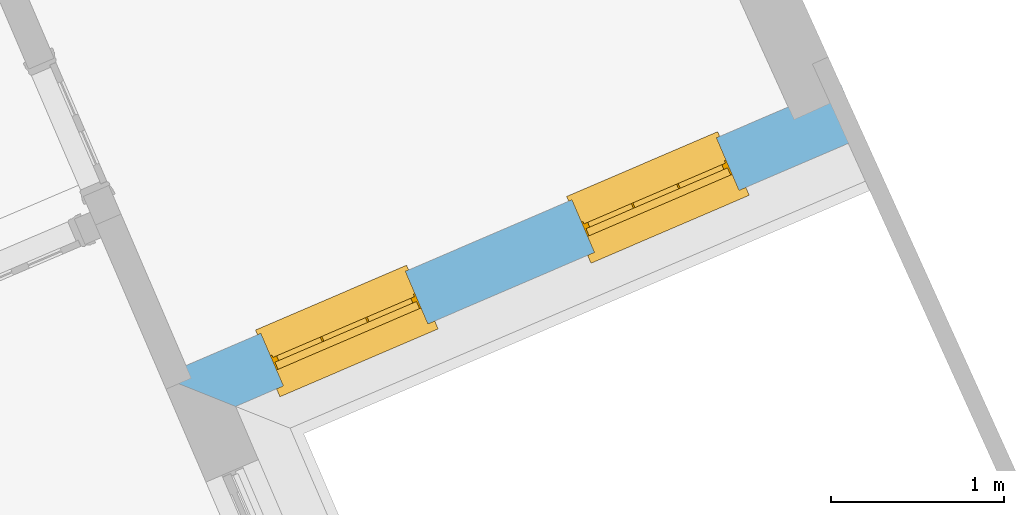
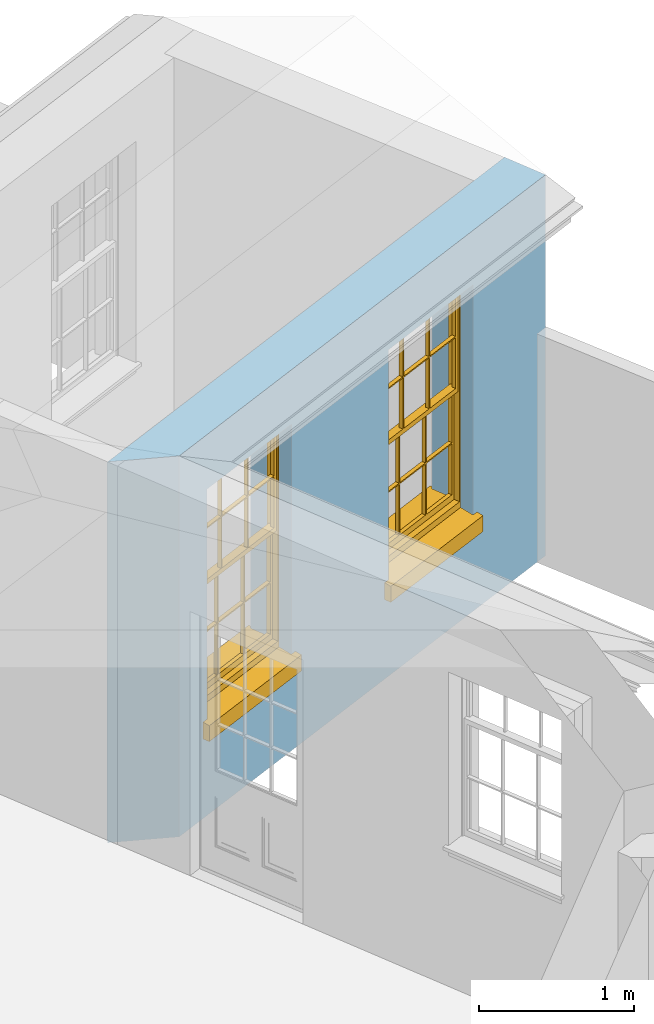
# One storey, part 14 of 19: 2 windows, 2 openings, plus 1 element that does not belong to this part.
"""IFC2X3 building model written with IfcOpenShell, lengths in metres."""

from ifc_helpers import new_model, si_unit, frame, origin, place, context, subcontext, project, spatial, polyline, outline, extrude, faceted_brep, material, layer, layer_set, layer_usage, element, fill, save


model = new_model("IFC2X3")

# Units and contexts
model_context = context("Model", 3, world=origin())
body_context = subcontext(model_context, "Body", "Model", "MODEL_VIEW")
ifc_project = project(units=[si_unit("PLANEANGLEUNIT", "RADIAN"), si_unit("MASSUNIT", "GRAM", prefix="KILO"), si_unit("FORCEUNIT", "NEWTON", prefix="KILO"), si_unit("LENGTHUNIT", "METRE")], contexts=[model_context])

# Site, building, storey
site_placement = place(None, origin())
site = spatial("IfcSite", under=ifc_project, at=site_placement, CompositionType="ELEMENT")
building_placement = place(None, origin())
building = spatial("IfcBuilding", under=site, at=building_placement, Name="Building plot-0", CompositionType="ELEMENT")
storey_placement = place(None, origin())
storey = spatial("IfcBuildingStorey", under=building, at=storey_placement, Name="Floor 0", CompositionType="ELEMENT", Elevation=0.0)

# Wall, openings, windows
ifc_material = material(Name="Masonry")
ifc_layer = layer(ifc_material, 0.33, ventilated=False)
ifc_layer_set = layer_set([ifc_layer], Name="My Wall")
ifc_layer_usage = layer_usage(ifc_layer_set, "AXIS2", "NEGATIVE", 0.08)
wall_placement = place(storey_placement, origin())
wall = element("IfcWallStandardCase", 1, at=wall_placement, inside=storey, material=ifc_layer_usage, Name="exterior", context=body_context, shape_type="SweptSolid", body=[
    extrude(outline(polyline([(22.5638042639667, 27.6756383909319), (22.9972229109118, 27.5025826875291), (26.6256869190706, 29.0603032558596), (26.4955054472994, 29.3635404310336), (22.5638042639667, 27.6756383909319)])), origin(), (0.0, 0.0, 1.0), 3.0),
])
opening_1_placement = place(storey_placement, frame((0.0, 0.0, 0.75)))
opening_1 = element("IfcOpeningElement", 2, at=opening_1_placement, cuts=wall, Name="Opening", ObjectType="Opening", context=body_context, shape_type="SweptSolid", body=[
    extrude(outline(polyline([(23.2728930701609, 27.6209294800484), (24.1090925532164, 27.9799147506902), (23.9789110814452, 28.2831519258642), (23.1427115983897, 27.9241666552224), (23.2728930701609, 27.6209294800484)])), origin(), (0.0, 0.0, 1.0), 1.82),
])
opening_2_placement = place(storey_placement, frame((0.0, 0.0, 0.75)))
opening_2 = element("IfcOpeningElement", 3, at=opening_2_placement, cuts=wall, Name="Opening", ObjectType="Opening", context=body_context, shape_type="SweptSolid", body=[
    extrude(outline(polyline([(25.0707460427957, 28.3927581513567), (25.9069455258511, 28.7517434219985), (25.7767640540799, 29.0549805971725), (24.9405645710245, 28.6959953265307), (25.0707460427957, 28.3927581513567)])), origin(), (0.0, 0.0, 1.0), 1.82),
])
window_1_placement = place(storey_placement, frame((23.1742707430615, 27.850654612756, 0.75), z_axis=(0.0, 0.0, 1.0), x_axis=(0.836199483055477, 0.358985270641782, 0.0)))
window_1 = element("IfcWindow", 4, at=window_1_placement, inside=storey, Name="toilet outside window", OverallHeight=1.82, OverallWidth=0.91, context=body_context, shape_type="Brep", held_by="IfcProductRepresentation", body=[
    faceted_brep([(0.033125, -0.105, 0.975209), (0.01, -0.105, 0.975209), (0.033125, -0.105, 1.376042), (0.876875, -0.105, 0.975209), (0.876875, -0.105, 1.376042), (0.9, -0.105, 0.975209), (0.876875, -0.105, 1.386042), (0.876875, -0.105, 1.786875), (0.9, -0.105, 1.81), (0.033125, -0.105, 1.786875), (0.033125, -0.105, 1.386042), (0.01, -0.105, 1.81), (0.876875, -0.135, 1.376042), (0.876875, -0.135, 0.975209), (0.9, -0.135, 0.937083), (0.033125, -0.135, 1.786875), (0.01, -0.135, 1.81), (0.033125, -0.135, 1.386042), (0.01, -0.135, 0.937083), (0.033125, -0.135, 0.975209), (0.033125, -0.135, 1.376042), (0.876875, -0.135, 1.786875), (0.876875, -0.135, 1.386042), (0.9, -0.135, 1.81), (0.033125, -0.105, 0.937083), (0.01, -0.105, 0.937083), (0.033125, -0.105, 0.53625), (0.876875, -0.105, 0.937083), (0.876875, -0.105, 0.53625), (0.9, -0.105, 0.937083), (0.876875, -0.105, 0.52625), (0.876875, -0.105, 0.125417), (0.9, -0.105, 0.077167), (0.033125, -0.105, 0.125417), (0.033125, -0.105, 0.52625), (0.01, -0.105, 0.077167), (-0.0425, -0.25, 0.01), (-0.0425, -0.3, 0.001667), (0.0, -0.25, 0.01), (0.9525, -0.25, 0.01), (0.91, -0.25, 0.01), (0.9525, -0.3, 0.001667), (-0.02, 0.08, 0.077167), (0.0, 0.08, 0.077167), (-0.02, 0.11, 0.077167), (0.0, -0.06, 0.077167), (0.01, -0.06, 0.077167), (0.91, -0.06, 0.077167), (0.91, 0.08, 0.077167), (0.9, -0.06, 0.077167), (0.93, 0.08, 0.077167), (0.93, 0.11, 0.077167), (0.01, -0.075, 0.975209), (0.9, -0.075, 0.975209), (0.876875, -0.075, 0.125417), (0.876875, -0.075, 0.52625), (0.9, -0.075, 0.077167), (0.876875, -0.075, 0.53625), (0.876875, -0.075, 0.937083), (0.033125, -0.075, 0.125417), (0.01, -0.075, 0.077167), (0.033125, -0.075, 0.52625), (0.033125, -0.075, 0.937083), (0.033125, -0.075, 0.53625), (-0.02, 0.08, 0.052167), (-0.02, 0.11, 0.052167), (0.93, 0.11, 0.052167), (0.93, 0.08, 0.052167), (0.91, 0.08, 0.052167), (0.0, 0.08, 0.052167), (0.91, -0.15, 0.026667), (0.0, -0.15, 0.026667), (-0.0425, -0.3, -0.123333), (0.9525, -0.3, -0.123333), (-0.0425, -0.25, -0.123333), (0.9525, -0.25, -0.123333), (0.01, -0.06, 1.81), (0.9, -0.06, 1.81), (0.0, -0.06, 1.82), (0.91, -0.06, 1.82), (0.01, -0.15, 0.077167), (0.9, -0.15, 0.077167), (0.592292, -0.105, 0.125417), (0.592292, -0.075, 0.125417), (0.317708, -0.075, 0.125417), (0.317708, -0.105, 0.125417), (0.592292, -0.105, 0.53625), (0.317708, -0.105, 0.53625), (0.317708, -0.105, 0.52625), (0.592292, -0.105, 0.52625), (0.592292, -0.075, 0.53625), (0.317708, -0.075, 0.53625), (0.592292, -0.135, 1.386042), (0.592292, -0.105, 1.386042), (0.317708, -0.105, 1.386042), (0.317708, -0.135, 1.386042), (0.317708, -0.135, 1.376042), (0.592292, -0.135, 1.376042), (0.317708, -0.105, 1.376042), (0.592292, -0.105, 1.376042), (0.602292, -0.135, 1.376042), (0.592292, -0.135, 0.975209), (0.602292, -0.135, 0.975209), (0.602292, -0.105, 0.975209), (0.592292, -0.105, 0.975209), (0.602292, -0.105, 1.376042), (0.602292, -0.075, 0.53625), (0.602292, -0.105, 0.53625), (0.317708, -0.075, 0.52625), (0.307708, -0.075, 0.125417), (0.307708, -0.075, 0.52625), (0.602292, -0.075, 0.52625), (0.602292, -0.075, 0.125417), (0.592292, -0.075, 0.52625), (0.307708, -0.075, 0.53625), (0.317708, -0.075, 0.937083), (0.307708, -0.075, 0.937083), (0.602292, -0.075, 0.937083), (0.592292, -0.075, 0.937083), (0.307708, -0.105, 0.52625), (0.307708, -0.105, 0.125417), (0.307708, -0.105, 0.53625), (0.307708, -0.105, 0.937083), (0.592292, -0.105, 0.937083), (0.317708, -0.105, 0.937083), (0.602292, -0.105, 0.937083), (0.602292, -0.105, 0.52625), (0.602292, -0.105, 0.125417), (0.307708, -0.135, 1.386042), (0.307708, -0.135, 1.376042), (0.307708, -0.135, 0.975209), (0.317708, -0.135, 0.975209), (0.317708, -0.135, 1.786875), (0.307708, -0.135, 1.786875), (0.602292, -0.135, 1.786875), (0.592292, -0.135, 1.786875), (0.602292, -0.135, 1.386042), (0.602292, -0.105, 1.386042), (0.307708, -0.105, 1.386042), (0.307708, -0.105, 1.786875), (0.317708, -0.105, 1.786875), (0.592292, -0.105, 1.786875), (0.602292, -0.105, 1.786875), (0.307708, -0.105, 1.376042), (0.317708, -0.105, 0.975209), (0.307708, -0.105, 0.975209), (0.91, -0.15, 1.82), (0.9, -0.15, 1.81), (0.01, -0.15, 1.81), (0.0, -0.15, 1.82), (0.91, -0.25, 0.0), (0.0, -0.25, 0.0), (0.91, 0.08, 0.0), (0.0, 0.08, 0.0)], [[[0, 1, 2]], [[3, 4, 5]], [[6, 7, 8]], [[9, 10, 11]], [[12, 13, 14]], [[15, 16, 17]], [[18, 19, 20]], [[21, 22, 23]], [[24, 25, 26]], [[27, 28, 29]], [[30, 31, 32]], [[33, 34, 35]], [[14, 27, 29]], [[25, 24, 18]], [[36, 37, 38]], [[39, 40, 41]], [[42, 43, 44]], [[45, 46, 43]], [[47, 48, 49]], [[50, 51, 48]], [[1, 0, 52]], [[5, 53, 3]], [[54, 55, 56]], [[57, 58, 53]], [[59, 60, 61]], [[62, 63, 52]], [[48, 43, 46, 49]], [[51, 44, 43, 48]], [[64, 42, 44, 65]], [[65, 44, 51, 66]], [[66, 51, 50, 67]], [[65, 66, 68, 69]], [[60, 56, 49, 46]], [[70, 71, 38, 40]], [[37, 41, 40, 38]], [[37, 72, 73, 41]], [[74, 75, 73, 72]], [[8, 11, 76, 77]], [[76, 78, 79, 77]], [[32, 35, 80, 81]], [[81, 80, 71, 70]], [[82, 83, 84, 85]], [[86, 87, 88, 89]], [[86, 90, 91, 87]], [[92, 93, 94, 95]], [[92, 95, 96, 97]], [[96, 98, 99, 97]], [[100, 97, 101, 102]], [[103, 104, 99, 105]], [[97, 99, 104, 101]], [[102, 103, 105, 100]], [[28, 57, 106, 107]], [[108, 84, 109, 110]], [[111, 112, 83, 113]], [[114, 110, 61, 63]], [[90, 113, 108, 91]], [[115, 91, 114, 116]], [[117, 106, 90, 118]], [[111, 106, 57, 55]], [[119, 110, 109, 120]], [[34, 61, 110, 119]], [[89, 113, 83, 82]], [[88, 108, 113, 89]], [[85, 84, 108, 88]], [[121, 114, 63, 26]], [[122, 116, 114, 121]], [[123, 118, 90, 86]], [[87, 91, 115, 124]], [[107, 106, 117, 125]], [[126, 111, 55, 30]], [[127, 112, 111, 126]], [[126, 30, 28, 107]], [[88, 119, 120, 85]], [[126, 89, 82, 127]], [[125, 123, 86, 107]], [[121, 26, 34, 119]], [[124, 122, 121, 87]], [[128, 17, 20, 129]], [[96, 129, 130, 131]], [[132, 133, 128, 95]], [[134, 135, 92, 136]], [[100, 12, 22, 136]], [[137, 6, 4, 105]], [[94, 138, 139, 140]], [[137, 93, 141, 142]], [[99, 98, 94, 93]], [[143, 2, 10, 138]], [[144, 145, 143, 98]], [[129, 143, 145, 130]], [[20, 2, 143, 129]], [[131, 144, 98, 96]], [[128, 138, 10, 17]], [[133, 139, 138, 128]], [[135, 141, 93, 92]], [[95, 94, 140, 132]], [[22, 6, 137, 136]], [[136, 137, 142, 134]], [[100, 105, 4, 12]], [[107, 86, 89, 126]], [[106, 111, 113, 90]], [[91, 108, 110, 114]], [[87, 121, 119, 88]], [[97, 100, 136, 92]], [[129, 96, 95, 128]], [[98, 143, 138, 94]], [[105, 99, 93, 137]], [[131, 101, 104, 144]], [[124, 115, 118, 123]], [[132, 140, 141, 135]], [[120, 109, 59, 33]], [[15, 9, 139, 133]], [[134, 142, 7, 21]], [[31, 54, 112, 127]], [[36, 74, 72, 37]], [[39, 41, 73, 75]], [[18, 14, 101, 131]], [[23, 16, 132, 135]], [[83, 56, 60, 84]], [[52, 53, 118, 115]], [[53, 52, 144, 104]], [[11, 8, 141, 140]], [[14, 18, 124, 123]], [[2, 1, 11, 10]], [[8, 5, 4, 6]], [[57, 53, 56, 55]], [[60, 52, 63, 61]], [[26, 25, 35, 34]], [[32, 29, 28, 30]], [[14, 23, 22, 12]], [[18, 20, 17, 16]], [[19, 0, 2, 20]], [[17, 10, 9, 15]], [[12, 4, 3, 13]], [[21, 7, 6, 22]], [[27, 58, 57, 28]], [[30, 55, 54, 31]], [[33, 59, 61, 34]], [[26, 63, 62, 24]], [[5, 8, 77, 53]], [[76, 11, 1, 52]], [[46, 45, 78, 76]], [[49, 77, 79, 47]], [[70, 146, 147, 81]], [[71, 80, 148, 149]], [[19, 130, 145, 0]], [[102, 13, 3, 103]], [[116, 122, 24, 62]], [[29, 32, 81, 14]], [[80, 35, 25, 18]], [[60, 46, 76, 52]], [[77, 49, 56, 53]], [[23, 14, 81, 147]], [[16, 148, 80, 18]], [[35, 85, 120]], [[120, 33, 35]], [[127, 82, 32]], [[32, 31, 127]], [[32, 82, 85, 35]], [[102, 101, 14]], [[14, 13, 102]], [[18, 131, 130]], [[130, 19, 18]], [[134, 21, 23]], [[23, 135, 134]], [[16, 15, 133]], [[133, 132, 16]], [[11, 140, 139]], [[139, 9, 11]], [[142, 141, 8]], [[8, 7, 142]], [[23, 147, 148, 16]], [[146, 149, 148, 147]], [[52, 115, 116]], [[116, 62, 52]], [[118, 53, 117]], [[58, 117, 53]], [[27, 125, 117, 58]], [[56, 83, 112]], [[112, 54, 56]], [[109, 84, 60]], [[60, 59, 109]], [[125, 27, 14]], [[14, 123, 125]], [[122, 124, 18]], [[18, 24, 122]], [[145, 144, 52]], [[52, 0, 145]], [[103, 3, 53]], [[53, 104, 103]], [[79, 78, 149, 146]], [[78, 45, 71, 149]], [[146, 70, 47, 79]], [[150, 75, 74, 151]], [[68, 66, 67]], [[48, 68, 67, 50]], [[69, 64, 65]], [[42, 64, 69, 43]], [[69, 68, 152, 153]], [[70, 68, 48, 47]], [[150, 152, 68, 70]], [[43, 69, 71, 45]], [[69, 153, 151, 71]], [[152, 150, 151, 153]], [[38, 151, 74, 36]], [[71, 151, 38]], [[39, 75, 150, 40]], [[40, 150, 70]]]),
])
fill(opening_1, window_1)
window_2_placement = place(storey_placement, frame((24.9721237156963, 28.6224832840643, 0.75), z_axis=(0.0, 0.0, 1.0), x_axis=(0.836199483055477, 0.358985270641782, 0.0)))
window_2 = element("IfcWindow", 5, at=window_2_placement, inside=storey, Name="toilet outside window", OverallHeight=1.82, OverallWidth=0.91, context=body_context, shape_type="Brep", held_by="IfcProductRepresentation", body=[
    faceted_brep([(0.033125, -0.105, 0.975209), (0.01, -0.105, 0.975209), (0.033125, -0.105, 1.376042), (0.876875, -0.105, 0.975209), (0.876875, -0.105, 1.376042), (0.9, -0.105, 0.975209), (0.876875, -0.105, 1.386042), (0.876875, -0.105, 1.786875), (0.9, -0.105, 1.81), (0.033125, -0.105, 1.786875), (0.033125, -0.105, 1.386042), (0.01, -0.105, 1.81), (0.876875, -0.135, 1.376042), (0.876875, -0.135, 0.975209), (0.9, -0.135, 0.937083), (0.033125, -0.135, 1.786875), (0.01, -0.135, 1.81), (0.033125, -0.135, 1.386042), (0.01, -0.135, 0.937083), (0.033125, -0.135, 0.975209), (0.033125, -0.135, 1.376042), (0.876875, -0.135, 1.786875), (0.876875, -0.135, 1.386042), (0.9, -0.135, 1.81), (0.033125, -0.105, 0.937083), (0.01, -0.105, 0.937083), (0.033125, -0.105, 0.53625), (0.876875, -0.105, 0.937083), (0.876875, -0.105, 0.53625), (0.9, -0.105, 0.937083), (0.876875, -0.105, 0.52625), (0.876875, -0.105, 0.125417), (0.9, -0.105, 0.077167), (0.033125, -0.105, 0.125417), (0.033125, -0.105, 0.52625), (0.01, -0.105, 0.077167), (-0.0425, -0.25, 0.01), (-0.0425, -0.3, 0.001667), (0.0, -0.25, 0.01), (0.9525, -0.25, 0.01), (0.91, -0.25, 0.01), (0.9525, -0.3, 0.001667), (-0.02, 0.08, 0.077167), (0.0, 0.08, 0.077167), (-0.02, 0.11, 0.077167), (0.0, -0.06, 0.077167), (0.01, -0.06, 0.077167), (0.91, -0.06, 0.077167), (0.91, 0.08, 0.077167), (0.9, -0.06, 0.077167), (0.93, 0.08, 0.077167), (0.93, 0.11, 0.077167), (0.01, -0.075, 0.975209), (0.9, -0.075, 0.975209), (0.876875, -0.075, 0.125417), (0.876875, -0.075, 0.52625), (0.9, -0.075, 0.077167), (0.876875, -0.075, 0.53625), (0.876875, -0.075, 0.937083), (0.033125, -0.075, 0.125417), (0.01, -0.075, 0.077167), (0.033125, -0.075, 0.52625), (0.033125, -0.075, 0.937083), (0.033125, -0.075, 0.53625), (-0.02, 0.08, 0.052167), (-0.02, 0.11, 0.052167), (0.93, 0.11, 0.052167), (0.93, 0.08, 0.052167), (0.91, 0.08, 0.052167), (0.0, 0.08, 0.052167), (0.91, -0.15, 0.026667), (0.0, -0.15, 0.026667), (-0.0425, -0.3, -0.123333), (0.9525, -0.3, -0.123333), (-0.0425, -0.25, -0.123333), (0.9525, -0.25, -0.123333), (0.01, -0.06, 1.81), (0.9, -0.06, 1.81), (0.0, -0.06, 1.82), (0.91, -0.06, 1.82), (0.01, -0.15, 0.077167), (0.9, -0.15, 0.077167), (0.592292, -0.105, 0.125417), (0.592292, -0.075, 0.125417), (0.317708, -0.075, 0.125417), (0.317708, -0.105, 0.125417), (0.592292, -0.105, 0.53625), (0.317708, -0.105, 0.53625), (0.317708, -0.105, 0.52625), (0.592292, -0.105, 0.52625), (0.592292, -0.075, 0.53625), (0.317708, -0.075, 0.53625), (0.592292, -0.135, 1.386042), (0.592292, -0.105, 1.386042), (0.317708, -0.105, 1.386042), (0.317708, -0.135, 1.386042), (0.317708, -0.135, 1.376042), (0.592292, -0.135, 1.376042), (0.317708, -0.105, 1.376042), (0.592292, -0.105, 1.376042), (0.602292, -0.135, 1.376042), (0.592292, -0.135, 0.975209), (0.602292, -0.135, 0.975209), (0.602292, -0.105, 0.975209), (0.592292, -0.105, 0.975209), (0.602292, -0.105, 1.376042), (0.602292, -0.075, 0.53625), (0.602292, -0.105, 0.53625), (0.317708, -0.075, 0.52625), (0.307708, -0.075, 0.125417), (0.307708, -0.075, 0.52625), (0.602292, -0.075, 0.52625), (0.602292, -0.075, 0.125417), (0.592292, -0.075, 0.52625), (0.307708, -0.075, 0.53625), (0.317708, -0.075, 0.937083), (0.307708, -0.075, 0.937083), (0.602292, -0.075, 0.937083), (0.592292, -0.075, 0.937083), (0.307708, -0.105, 0.52625), (0.307708, -0.105, 0.125417), (0.307708, -0.105, 0.53625), (0.307708, -0.105, 0.937083), (0.592292, -0.105, 0.937083), (0.317708, -0.105, 0.937083), (0.602292, -0.105, 0.937083), (0.602292, -0.105, 0.52625), (0.602292, -0.105, 0.125417), (0.307708, -0.135, 1.386042), (0.307708, -0.135, 1.376042), (0.307708, -0.135, 0.975209), (0.317708, -0.135, 0.975209), (0.317708, -0.135, 1.786875), (0.307708, -0.135, 1.786875), (0.602292, -0.135, 1.786875), (0.592292, -0.135, 1.786875), (0.602292, -0.135, 1.386042), (0.602292, -0.105, 1.386042), (0.307708, -0.105, 1.386042), (0.307708, -0.105, 1.786875), (0.317708, -0.105, 1.786875), (0.592292, -0.105, 1.786875), (0.602292, -0.105, 1.786875), (0.307708, -0.105, 1.376042), (0.317708, -0.105, 0.975209), (0.307708, -0.105, 0.975209), (0.91, -0.15, 1.82), (0.9, -0.15, 1.81), (0.01, -0.15, 1.81), (0.0, -0.15, 1.82), (0.91, -0.25, 0.0), (0.0, -0.25, 0.0), (0.91, 0.08, 0.0), (0.0, 0.08, 0.0)], [[[0, 1, 2]], [[3, 4, 5]], [[6, 7, 8]], [[9, 10, 11]], [[12, 13, 14]], [[15, 16, 17]], [[18, 19, 20]], [[21, 22, 23]], [[24, 25, 26]], [[27, 28, 29]], [[30, 31, 32]], [[33, 34, 35]], [[14, 27, 29]], [[25, 24, 18]], [[36, 37, 38]], [[39, 40, 41]], [[42, 43, 44]], [[45, 46, 43]], [[47, 48, 49]], [[50, 51, 48]], [[1, 0, 52]], [[5, 53, 3]], [[54, 55, 56]], [[57, 58, 53]], [[59, 60, 61]], [[62, 63, 52]], [[48, 43, 46, 49]], [[51, 44, 43, 48]], [[64, 42, 44, 65]], [[65, 44, 51, 66]], [[66, 51, 50, 67]], [[65, 66, 68, 69]], [[60, 56, 49, 46]], [[70, 71, 38, 40]], [[37, 41, 40, 38]], [[37, 72, 73, 41]], [[74, 75, 73, 72]], [[8, 11, 76, 77]], [[76, 78, 79, 77]], [[32, 35, 80, 81]], [[81, 80, 71, 70]], [[82, 83, 84, 85]], [[86, 87, 88, 89]], [[86, 90, 91, 87]], [[92, 93, 94, 95]], [[92, 95, 96, 97]], [[96, 98, 99, 97]], [[100, 97, 101, 102]], [[103, 104, 99, 105]], [[97, 99, 104, 101]], [[102, 103, 105, 100]], [[28, 57, 106, 107]], [[108, 84, 109, 110]], [[111, 112, 83, 113]], [[114, 110, 61, 63]], [[90, 113, 108, 91]], [[115, 91, 114, 116]], [[117, 106, 90, 118]], [[111, 106, 57, 55]], [[119, 110, 109, 120]], [[34, 61, 110, 119]], [[89, 113, 83, 82]], [[88, 108, 113, 89]], [[85, 84, 108, 88]], [[121, 114, 63, 26]], [[122, 116, 114, 121]], [[123, 118, 90, 86]], [[87, 91, 115, 124]], [[107, 106, 117, 125]], [[126, 111, 55, 30]], [[127, 112, 111, 126]], [[126, 30, 28, 107]], [[88, 119, 120, 85]], [[126, 89, 82, 127]], [[125, 123, 86, 107]], [[121, 26, 34, 119]], [[124, 122, 121, 87]], [[128, 17, 20, 129]], [[96, 129, 130, 131]], [[132, 133, 128, 95]], [[134, 135, 92, 136]], [[100, 12, 22, 136]], [[137, 6, 4, 105]], [[94, 138, 139, 140]], [[137, 93, 141, 142]], [[99, 98, 94, 93]], [[143, 2, 10, 138]], [[144, 145, 143, 98]], [[129, 143, 145, 130]], [[20, 2, 143, 129]], [[131, 144, 98, 96]], [[128, 138, 10, 17]], [[133, 139, 138, 128]], [[135, 141, 93, 92]], [[95, 94, 140, 132]], [[22, 6, 137, 136]], [[136, 137, 142, 134]], [[100, 105, 4, 12]], [[107, 86, 89, 126]], [[106, 111, 113, 90]], [[91, 108, 110, 114]], [[87, 121, 119, 88]], [[97, 100, 136, 92]], [[129, 96, 95, 128]], [[98, 143, 138, 94]], [[105, 99, 93, 137]], [[131, 101, 104, 144]], [[124, 115, 118, 123]], [[132, 140, 141, 135]], [[120, 109, 59, 33]], [[15, 9, 139, 133]], [[134, 142, 7, 21]], [[31, 54, 112, 127]], [[36, 74, 72, 37]], [[39, 41, 73, 75]], [[18, 14, 101, 131]], [[23, 16, 132, 135]], [[83, 56, 60, 84]], [[52, 53, 118, 115]], [[53, 52, 144, 104]], [[11, 8, 141, 140]], [[14, 18, 124, 123]], [[2, 1, 11, 10]], [[8, 5, 4, 6]], [[57, 53, 56, 55]], [[60, 52, 63, 61]], [[26, 25, 35, 34]], [[32, 29, 28, 30]], [[14, 23, 22, 12]], [[18, 20, 17, 16]], [[19, 0, 2, 20]], [[17, 10, 9, 15]], [[12, 4, 3, 13]], [[21, 7, 6, 22]], [[27, 58, 57, 28]], [[30, 55, 54, 31]], [[33, 59, 61, 34]], [[26, 63, 62, 24]], [[5, 8, 77, 53]], [[76, 11, 1, 52]], [[46, 45, 78, 76]], [[49, 77, 79, 47]], [[70, 146, 147, 81]], [[71, 80, 148, 149]], [[19, 130, 145, 0]], [[102, 13, 3, 103]], [[116, 122, 24, 62]], [[29, 32, 81, 14]], [[80, 35, 25, 18]], [[60, 46, 76, 52]], [[77, 49, 56, 53]], [[23, 14, 81, 147]], [[16, 148, 80, 18]], [[35, 85, 120]], [[120, 33, 35]], [[127, 82, 32]], [[32, 31, 127]], [[32, 82, 85, 35]], [[102, 101, 14]], [[14, 13, 102]], [[18, 131, 130]], [[130, 19, 18]], [[134, 21, 23]], [[23, 135, 134]], [[16, 15, 133]], [[133, 132, 16]], [[11, 140, 139]], [[139, 9, 11]], [[142, 141, 8]], [[8, 7, 142]], [[23, 147, 148, 16]], [[146, 149, 148, 147]], [[52, 115, 116]], [[116, 62, 52]], [[118, 53, 117]], [[58, 117, 53]], [[27, 125, 117, 58]], [[56, 83, 112]], [[112, 54, 56]], [[109, 84, 60]], [[60, 59, 109]], [[125, 27, 14]], [[14, 123, 125]], [[122, 124, 18]], [[18, 24, 122]], [[145, 144, 52]], [[52, 0, 145]], [[103, 3, 53]], [[53, 104, 103]], [[79, 78, 149, 146]], [[78, 45, 71, 149]], [[146, 70, 47, 79]], [[150, 75, 74, 151]], [[68, 66, 67]], [[48, 68, 67, 50]], [[69, 64, 65]], [[42, 64, 69, 43]], [[69, 68, 152, 153]], [[70, 68, 48, 47]], [[150, 152, 68, 70]], [[43, 69, 71, 45]], [[69, 153, 151, 71]], [[152, 150, 151, 153]], [[38, 151, 74, 36]], [[71, 151, 38]], [[39, 75, 150, 40]], [[40, 150, 70]]]),
])
fill(opening_2, window_2)

save(model, "model.ifc")
